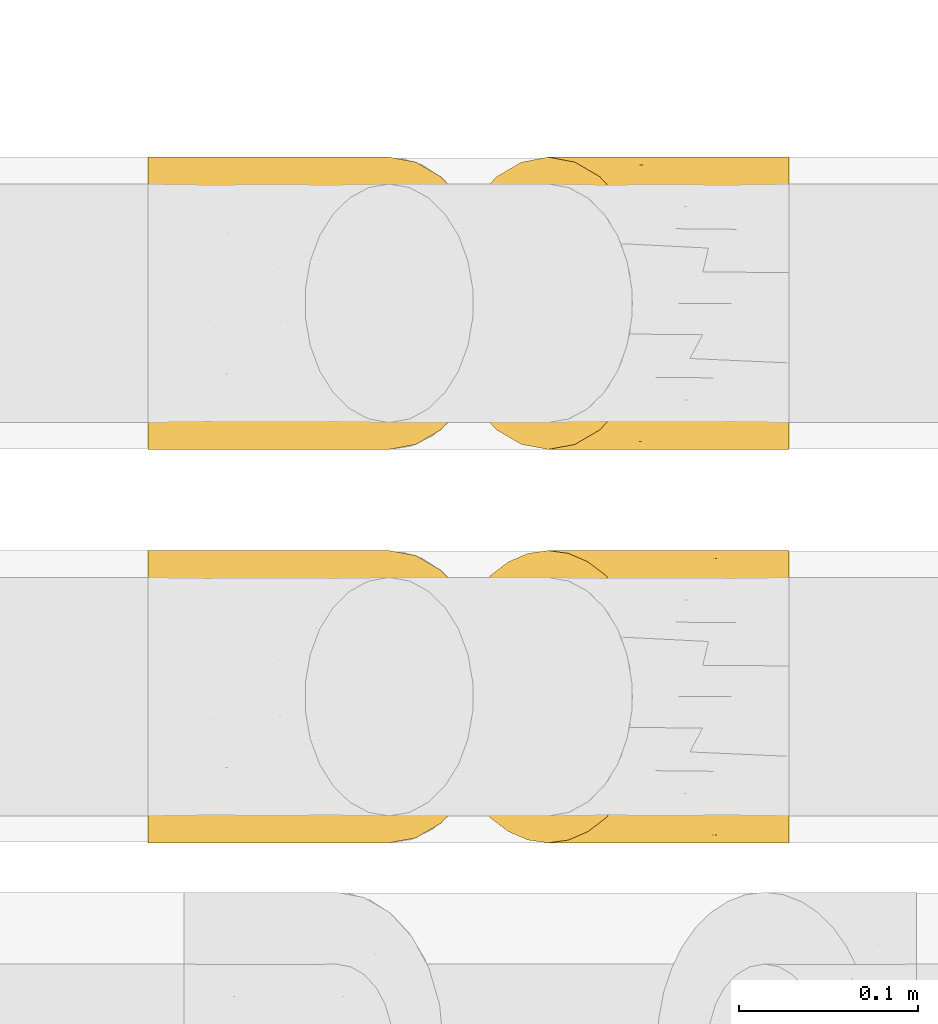
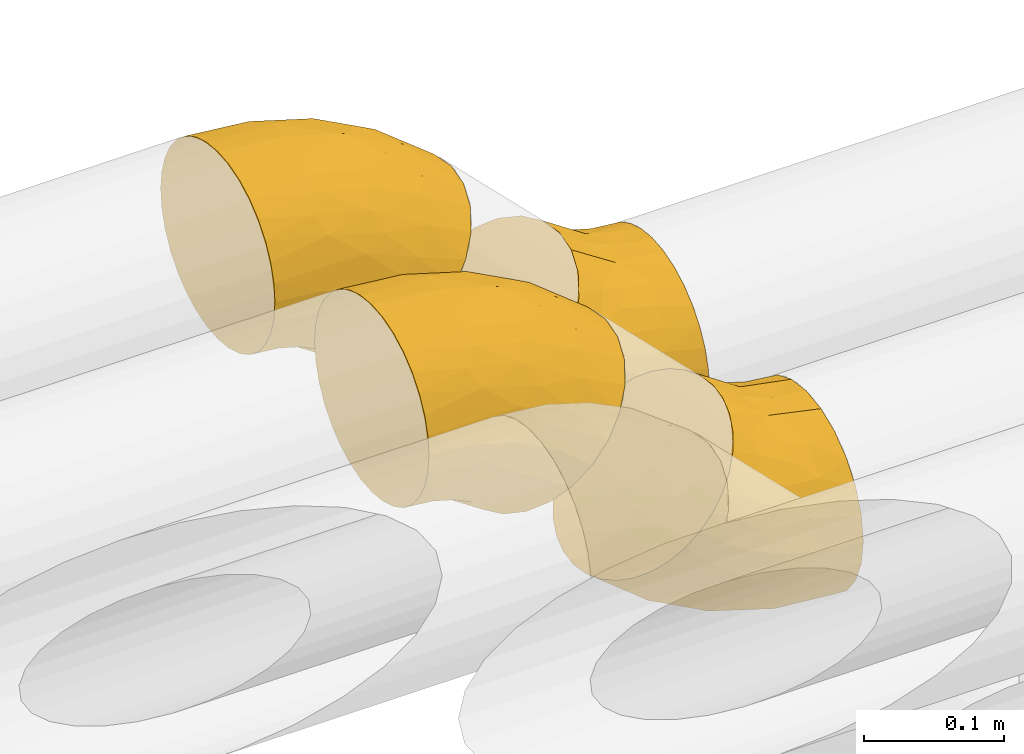
# One storey, part 28 of 93: 4 coverings.
"""IFC2X3 building model written with IfcOpenShell, lengths in millimetres."""

import ifcopenshell
import ifcopenshell.guid

model = None  # the IFC model being written
_history = None  # IfcOwnerHistory: only IFC2X3 demands one
_inside = {}  # id of a spatial element -> (the spatial element, [elements in it])
_under = {}  # id of a project, library or spatial element -> (it, [spatial elements below it])
_declared = {}  # id of a project -> (the project, [libraries it declares])
_typed = {}  # id of a type object -> (the type object, [elements of that type])
_made_of = {}  # id of a material, layer set ... -> (it, [elements and type objects made of it])


def new_model(schema):
    """Start an empty IFC model of exactly this schema.

    Asked for "IFC4X3", IfcOpenShell would pick the latest addendum, in which some entities
    have other attributes; the version numbers below select the first issue.
    IFC2X3 requires an IfcOwnerHistory on every rooted entity: one is made here for all.
    """
    global model, _history
    if schema == "IFC4X3":
        model = ifcopenshell.file(schema_version=(4, 3, 0, 0))
    else:
        model = ifcopenshell.file(schema=schema)
    _inside.clear()
    _under.clear()
    _declared.clear()
    _typed.clear()
    _made_of.clear()
    _history = None
    if model.schema == "IFC2X3":
        org = make("IfcOrganization", Name="unknown")
        user = make(
            "IfcPersonAndOrganization",
            ThePerson=make("IfcPerson", FamilyName="unknown"),
            TheOrganization=org,
        )
        app = make(
            "IfcApplication",
            ApplicationDeveloper=org,
            Version="unknown",
            ApplicationFullName="unknown",
            ApplicationIdentifier="unknown",
        )
        _history = make(
            "IfcOwnerHistory",
            OwningUser=user,
            OwningApplication=app,
            ChangeAction="ADDED",
            CreationDate=0,
        )
    return model


def make(cls, **values):
    """One entity of the class cls with the attributes given. An attribute that is None is left unset."""
    return model.create_entity(
        cls, **{name: value for name, value in values.items() if value is not None}
    )


def entity(cls, *values):
    """Any entity or typed value of the class cls, its attributes in the order of the schema. None: left unset."""
    e = model.create_entity(cls)
    for i, value in enumerate(values):
        if value is not None:
            e[i] = value
    return e


def rooted(cls, **values):
    """An entity with a GlobalId (a new one), such as an element, a storey or a relation."""
    return make(cls, GlobalId=ifcopenshell.guid.new(), OwnerHistory=_history, **values)


def si_unit(unit_type, name, prefix=None):
    """IfcSIUnit, for example si_unit("LENGTHUNIT", "METRE", prefix="MILLI")."""
    return make("IfcSIUnit", UnitType=unit_type, Prefix=prefix, Name=name)


def converted_unit(unit_type, name, factor, base, dimensions=None, offset=None):
    """IfcConversionBasedUnit, such as the inch: factor (a typed value) times the base unit."""
    return make(
        "IfcConversionBasedUnit"
        if offset is None
        else "IfcConversionBasedUnitWithOffset",
        ConversionOffset=offset,
        Dimensions=None
        if dimensions is None
        else entity("IfcDimensionalExponents", *dimensions),
        UnitType=unit_type,
        Name=name,
        ConversionFactor=make(
            "IfcMeasureWithUnit", ValueComponent=factor, UnitComponent=base
        ),
    )


def derived_unit(unit_type, elements):
    """IfcDerivedUnit: a product of units, each with its exponent."""
    return make(
        "IfcDerivedUnit",
        Elements=[
            make("IfcDerivedUnitElement", Unit=unit, Exponent=power)
            for unit, power in elements
        ],
        UnitType=unit_type,
    )


def assignment(units):
    """IfcUnitAssignment: the units of a project."""
    return None if units is None else make("IfcUnitAssignment", Units=units)


def point(xyz):
    """IfcCartesianPoint."""
    return None if xyz is None else make("IfcCartesianPoint", Coordinates=xyz)


def direction(xyz):
    """IfcDirection."""
    return None if xyz is None else make("IfcDirection", DirectionRatios=xyz)


def frame(location, z_axis=None, x_axis=None):
    """IfcAxis2Placement3D, a coordinate frame: its origin and axes. An axis left out is left unset."""
    return make(
        "IfcAxis2Placement3D",
        Location=point(location),
        Axis=direction(z_axis),
        RefDirection=direction(x_axis),
    )


def origin():
    """The frame at (0, 0, 0) with its axes left unset."""
    return frame((0.0, 0.0, 0.0))


def place(relative_to, where):
    """IfcLocalPlacement: puts the frame where relative to a parent placement (None: the world)."""
    return make(
        "IfcLocalPlacement", PlacementRelTo=relative_to, RelativePlacement=where
    )


def context(
    kind, dimensions, precision=None, world=None, true_north=None, identifier=None
):
    """IfcGeometricRepresentationContext, for example the 3D "Model" context."""
    return make(
        "IfcGeometricRepresentationContext",
        ContextIdentifier=identifier,
        ContextType=kind,
        CoordinateSpaceDimension=dimensions,
        Precision=precision,
        WorldCoordinateSystem=world,
        TrueNorth=true_north,
    )


def subcontext(parent, identifier, kind, view, scale=None):
    """IfcGeometricRepresentationSubContext, for example "Body" below "Model"."""
    return make(
        "IfcGeometricRepresentationSubContext",
        ContextIdentifier=identifier,
        ContextType=kind,
        ParentContext=parent,
        TargetScale=scale,
        TargetView=view,
    )


def project(units=None, contexts=None):
    """IfcProject with its units and contexts."""
    return rooted(
        "IfcProject",
        Name="project",
        RepresentationContexts=contexts,
        UnitsInContext=assignment(units),
    )


def spatial(cls, under=None, at=None, **own):
    """A site, building, storey or space (cls), placed at a placement, below another one or the project."""
    s = rooted(cls, ObjectPlacement=at, **own)
    if under is not None:
        _under.setdefault(under.id(), (under, []))[1].append(s)
    return s


def faces_of(points, faces, orient=None, outer=None):
    """IfcFace entities. A face is a list of loops; a loop is a list of indices into points, from 0.

    orient and outer hold one flag for each loop. By default every Orientation is true, the
    first loop of a face is its IfcFaceOuterBound and the others are IfcFaceBound.
    """
    made = []
    for i, loops in enumerate(faces):
        bounds = []
        for j, loop in enumerate(loops):
            is_outer = j == 0 if outer is None else outer[i][j]
            bounds.append(
                make(
                    "IfcFaceOuterBound" if is_outer else "IfcFaceBound",
                    Bound=make("IfcPolyLoop", Polygon=[points[k] for k in loop]),
                    Orientation=True if orient is None else orient[i][j],
                )
            )
        made.append(make("IfcFace", Bounds=bounds))
    return made


def faceted_brep(points, faces, orient=None, outer=None, voids=None):
    """IfcFacetedBrep: a solid bounded by flat faces; with voids (closed shells), ...WithVoids."""
    shared = [point(p) for p in points]
    hull = make("IfcClosedShell", CfsFaces=faces_of(shared, faces, orient, outer))
    if voids is None:
        return make("IfcFacetedBrep", Outer=hull)
    return make(
        "IfcFacetedBrepWithVoids",
        Outer=hull,
        Voids=[
            make(cls, CfsFaces=faces_of(shared, fs, o, b)) for cls, fs, o, b in voids
        ],
    )


def shape(context_of_items, identifier, shape_type, items):
    """IfcShapeRepresentation: the items that make up one representation, for example the "Body"."""
    return make(
        "IfcShapeRepresentation",
        ContextOfItems=context_of_items,
        RepresentationIdentifier=identifier,
        RepresentationType=shape_type,
        Items=items,
    )


def made_of(thing, what):
    """Note that an element or type object is made of a material, layer set ...; save() writes the relation."""
    if what is not None:
        _made_of.setdefault(what.id(), (what, []))[1].append(thing)
    return thing


def element(
    cls,
    number,
    at=None,
    inside=None,
    cuts=None,
    type_object=None,
    material=None,
    context=None,
    identifier="Body",
    shape_type=None,
    held_by="IfcProductDefinitionShape",
    body=None,
    shapes=None,
    **own,
):
    """One element of the class cls, such as IfcWall. Its Tag is "e" and its number.

    at: its placement. inside: the storey or other place that contains it. cuts: it is an
    opening in that element (IfcRelVoidsElement). A single representation is given by context,
    identifier, shape_type and body (its items); several are given by shapes. held_by: the class
    of the entity that holds the representations. save() writes the other relations.
    """
    e = rooted(cls, Tag="e%d" % number, ObjectPlacement=at, **own)
    if body is not None:
        shapes = [shape(context, identifier, shape_type, body)]
    if shapes is not None:
        e.Representation = make(held_by, Representations=shapes)
    if inside is not None:
        _inside.setdefault(inside.id(), (inside, []))[1].append(e)
    if cuts is not None:
        rooted(
            "IfcRelVoidsElement", RelatingBuildingElement=cuts, RelatedOpeningElement=e
        )
    if type_object is not None:
        _typed.setdefault(type_object.id(), (type_object, []))[1].append(e)
    return made_of(e, material)


def aggregate(whole, parts):
    """IfcRelAggregates: a whole, such as a stair, and the parts it consists of."""
    return rooted("IfcRelAggregates", RelatingObject=whole, RelatedObjects=parts)


def save(model, path):
    """Write the relations noted so far, then the file.

    IfcRelAggregates (storeys below a building ...), IfcRelContainedInSpatialStructure (elements
    in a storey), IfcRelDefinesByType, IfcRelAssociatesMaterial and IfcRelDeclares: one each for
    every whole, place, type object, material and project.
    """
    for whole, parts in _under.values():
        aggregate(whole, parts)
    for where, things in _inside.values():
        rooted(
            "IfcRelContainedInSpatialStructure",
            RelatedElements=things,
            RelatingStructure=where,
        )
    for kind, things in _typed.values():
        rooted("IfcRelDefinesByType", RelatedObjects=things, RelatingType=kind)
    for what, things in _made_of.values():
        rooted("IfcRelAssociatesMaterial", RelatedObjects=things, RelatingMaterial=what)
    for by, libraries in _declared.values():
        rooted("IfcRelDeclares", RelatingContext=by, RelatedDefinitions=libraries)
    model.write(path)


model = new_model("IFC2X3")

# Units and contexts
model_context = context("Model", 3, precision=0.01, world=origin(), true_north=direction((6.12303176911189e-17, 1.0)))
body_context = subcontext(model_context, "Body", "Model", "MODEL_VIEW")
ifc_project = project(units=[si_unit("LENGTHUNIT", "METRE", prefix="MILLI"), si_unit("AREAUNIT", "SQUARE_METRE"), si_unit("VOLUMEUNIT", "CUBIC_METRE"), converted_unit("PLANEANGLEUNIT", "DEGREE", entity("IfcRatioMeasure", 0.0174532925199433), si_unit("PLANEANGLEUNIT", "RADIAN"), dimensions=[0, 0, 0, 0, 0, 0, 0]), si_unit("MASSUNIT", "GRAM", prefix="KILO"), derived_unit("MASSDENSITYUNIT", [(si_unit("MASSUNIT", "GRAM", prefix="KILO"), 1), (si_unit("LENGTHUNIT", "METRE"), -3)]), derived_unit("MOMENTOFINERTIAUNIT", [(si_unit("LENGTHUNIT", "METRE"), 4)]), si_unit("TIMEUNIT", "SECOND"), si_unit("FREQUENCYUNIT", "HERTZ"), si_unit("THERMODYNAMICTEMPERATUREUNIT", "DEGREE_CELSIUS"), derived_unit("THERMALTRANSMITTANCEUNIT", [(si_unit("MASSUNIT", "GRAM", prefix="KILO"), 1), (si_unit("THERMODYNAMICTEMPERATUREUNIT", "KELVIN"), -1), (si_unit("TIMEUNIT", "SECOND"), -3)]), derived_unit("VOLUMETRICFLOWRATEUNIT", [(si_unit("LENGTHUNIT", "METRE"), 3), (si_unit("TIMEUNIT", "SECOND"), -1)]), derived_unit("MASSFLOWRATEUNIT", [(si_unit("MASSUNIT", "GRAM", prefix="KILO"), 1), (si_unit("TIMEUNIT", "SECOND"), -1)]), derived_unit("ROTATIONALFREQUENCYUNIT", [(si_unit("TIMEUNIT", "SECOND"), -1)]), si_unit("ELECTRICCURRENTUNIT", "AMPERE"), si_unit("ELECTRICVOLTAGEUNIT", "VOLT"), si_unit("POWERUNIT", "WATT"), si_unit("FORCEUNIT", "NEWTON", prefix="KILO"), si_unit("ILLUMINANCEUNIT", "LUX"), si_unit("LUMINOUSFLUXUNIT", "LUMEN"), si_unit("LUMINOUSINTENSITYUNIT", "CANDELA"), derived_unit("USERDEFINED", [(si_unit("MASSUNIT", "GRAM", prefix="KILO"), -1), (si_unit("LENGTHUNIT", "METRE"), -2), (si_unit("TIMEUNIT", "SECOND"), 3), (si_unit("LUMINOUSFLUXUNIT", "LUMEN"), 1)]), derived_unit("LINEARVELOCITYUNIT", [(si_unit("LENGTHUNIT", "METRE"), 1), (si_unit("TIMEUNIT", "SECOND"), -1)]), si_unit("PRESSUREUNIT", "PASCAL"), derived_unit("USERDEFINED", [(si_unit("LENGTHUNIT", "METRE"), -2), (si_unit("MASSUNIT", "GRAM", prefix="KILO"), 1), (si_unit("TIMEUNIT", "SECOND"), -2)]), derived_unit("LINEARFORCEUNIT", [(si_unit("MASSUNIT", "GRAM", prefix="KILO"), 1), (si_unit("LENGTHUNIT", "METRE"), 1), (si_unit("TIMEUNIT", "SECOND"), -2), (si_unit("LENGTHUNIT", "METRE"), -1)]), derived_unit("PLANARFORCEUNIT", [(si_unit("MASSUNIT", "GRAM", prefix="KILO"), 1), (si_unit("LENGTHUNIT", "METRE"), 1), (si_unit("TIMEUNIT", "SECOND"), -2), (si_unit("LENGTHUNIT", "METRE"), -2)])], contexts=[model_context])

# Site, building, storey
site_placement = place(None, origin())
site = spatial("IfcSite", under=ifc_project, at=site_placement, CompositionType="ELEMENT")
building_placement = place(site_placement, origin())
building = spatial("IfcBuilding", under=site, at=building_placement, CompositionType="ELEMENT")
storey_placement = place(building_placement, frame((0.0, 0.0, -4200.0)))
storey = spatial("IfcBuildingStorey", under=building, at=storey_placement, CompositionType="ELEMENT", Elevation=-4200.0)

# Coverings
covering_1_placement = place(storey_placement, frame((22851.57, 9391.04, 2885.13)))
element("IfcCovering", 1, at=covering_1_placement, inside=storey, Name=":ADSK_", ObjectType=":ADSK_", PredefinedType="INSULATION", context=body_context, shape_type="Brep", body=[
    faceted_brep([(1.6, 67.2, 34.94), (1.6, 51.91, 39.58), (1.6, 37.82, 47.11), (1.6, 25.47, 57.25), (1.6, 15.33, 69.6), (1.6, 7.8, 83.69), (1.6, 3.16, 98.98), (1.6, 1.6, 114.87), (1.6, 3.16, 130.77), (1.6, 7.8, 146.06), (1.6, 15.33, 160.15), (1.6, 25.47, 172.5), (1.6, 37.82, 182.64), (1.6, 51.91, 190.17), (1.6, 67.2, 194.81), (1.6, 83.1, 196.37), (1.6, 99.0, 194.81), (1.6, 114.28, 190.17), (1.6, 128.37, 182.64), (1.6, 140.72, 172.5), (1.6, 150.86, 160.15), (1.6, 158.39, 146.06), (1.6, 163.03, 130.77), (1.6, 164.6, 114.87), (1.6, 163.03, 98.97), (1.6, 158.39, 83.69), (1.6, 150.86, 69.59), (1.6, 140.72, 57.24), (1.6, 128.37, 47.11), (1.6, 114.28, 39.58), (1.6, 98.99, 34.94), (1.6, 83.1, 33.37), (80.28, 104.19, 3.56), (86.04, 123.85, 9.32), (95.2, 140.72, 18.47), (107.13, 153.68, 30.41), (121.03, 161.82, 44.31), (135.95, 164.6, 59.22), (150.86, 161.82, 74.14), (164.76, 153.68, 88.04), (176.7, 140.72, 99.97), (185.85, 123.85, 109.13), (191.61, 104.19, 114.89), (193.57, 83.1, 116.85), (191.61, 62.0, 114.89), (185.85, 42.35, 109.13), (176.7, 25.47, 99.97), (164.76, 12.51, 88.04), (150.86, 4.37, 74.14), (135.95, 1.6, 59.22), (121.03, 4.37, 44.31), (107.13, 12.51, 30.41), (95.2, 25.47, 18.47), (86.04, 42.35, 9.32), (80.28, 62.0, 3.56), (78.32, 83.1, 1.6), (60.3, 60.17, 186.58), (100.98, 46.35, 168.1), (128.84, 64.11, 162.17), (152.43, 83.1, 150.62), (105.49, 83.1, 175.71), (139.75, 34.49, 139.7), (150.3, 49.6, 143.37), (51.57, 12.07, 149.35), (54.56, 83.1, 191.16), (107.15, 1.6, 82.85), (104.29, 3.08, 102.85), (74.31, 1.6, 100.41), (98.84, 12.62, 134.33), (91.29, 21.86, 151.55), (54.87, 45.58, 181.76), (137.35, 19.56, 124.06), (123.1, 7.29, 108.18), (79.11, 6.1, 127.27), (99.6, 33.79, 160.17), (44.25, 21.05, 163.94), (56.41, 32.43, 172.72), (38.66, 1.6, 111.22), (44.11, 62.69, 27.51), (22.65, 43.46, 41.78), (84.3, 5.92, 66.25), (50.27, 3.26, 91.51), (60.78, 8.71, 69.97), (79.3, 19.34, 40.4), (29.25, 18.22, 62.8), (56.24, 16.65, 56.8), (35.2, 9.42, 76.35), (30.87, 29.5, 50.1), (58.8, 28.17, 41.38), (68.75, 38.07, 26.81), (55.85, 83.1, 18.84), (46.59, 42.04, 35.68), (24.22, 4.27, 92.66), (29.68, 83.1, 29.68), (46.59, 124.15, 35.68), (58.8, 138.02, 41.38), (68.75, 128.12, 26.81), (50.27, 162.93, 91.51), (84.3, 160.27, 66.25), (60.78, 157.48, 69.97), (44.11, 103.5, 27.51), (35.2, 156.77, 76.35), (24.22, 161.92, 92.65), (56.24, 149.54, 56.8), (30.87, 136.69, 50.1), (107.15, 164.6, 82.85), (79.3, 146.85, 40.4), (74.31, 164.6, 100.41), (22.65, 122.73, 41.78), (38.66, 164.6, 111.22), (26.81, 147.88, 63.14), (79.1, 160.09, 127.27), (123.1, 158.9, 108.18), (104.28, 163.11, 102.85), (137.35, 146.63, 124.06), (51.57, 154.12, 149.35), (98.84, 153.57, 134.33), (91.29, 144.33, 151.55), (139.75, 131.7, 139.7), (150.3, 116.59, 143.37), (100.98, 119.84, 168.1), (60.3, 106.02, 186.58), (128.84, 102.08, 162.17), (56.41, 133.76, 172.72), (44.25, 145.14, 163.94), (99.62, 133.61, 159.15), (45.37, 120.65, 183.53)], [[[0, 1, 2, 3, 4, 5, 6, 7, 8, 9, 10, 11, 12, 13, 14, 15, 16, 17, 18, 19, 20, 21, 22, 23, 24, 25, 26, 27, 28, 29, 30, 31]], [[32, 33, 34, 35, 36, 37, 38, 39, 40, 41, 42, 43, 44, 45, 46, 47, 48, 49, 50, 51, 52, 53, 54, 55]], [[56, 57, 58]], [[44, 43, 59]], [[58, 59, 60]], [[60, 56, 58]], [[45, 61, 46]], [[61, 45, 62]], [[9, 63, 10]], [[64, 14, 56]], [[65, 66, 67]], [[68, 69, 63]], [[57, 61, 62]], [[70, 57, 56]], [[47, 71, 72]], [[49, 48, 66]], [[72, 66, 48]], [[9, 73, 63]], [[71, 69, 68]], [[44, 59, 58]], [[64, 56, 60]], [[74, 69, 61]], [[10, 63, 75]], [[70, 76, 74]], [[70, 12, 76]], [[14, 64, 15]], [[66, 72, 73]], [[61, 71, 46]], [[44, 58, 62]], [[71, 68, 72]], [[77, 8, 7]], [[67, 73, 77]], [[75, 69, 76]], [[75, 76, 11]], [[77, 73, 8]], [[73, 9, 8]], [[72, 68, 73]], [[71, 61, 69]], [[12, 11, 76]], [[74, 61, 57]], [[71, 47, 46]], [[56, 14, 13]], [[47, 72, 48]], [[68, 63, 73]], [[67, 66, 73]], [[66, 65, 49]], [[44, 62, 45]], [[57, 62, 58]], [[10, 75, 11]], [[63, 69, 75]], [[56, 13, 70]], [[12, 70, 13]], [[70, 74, 57]], [[69, 74, 76]], [[78, 79, 1]], [[50, 49, 65]], [[80, 67, 81]], [[82, 83, 80]], [[84, 85, 86]], [[85, 84, 87]], [[88, 89, 83]], [[50, 65, 80]], [[82, 86, 85]], [[87, 88, 85]], [[54, 90, 55]], [[89, 78, 54]], [[87, 79, 91]], [[0, 78, 1]], [[89, 54, 53]], [[54, 78, 90]], [[86, 5, 4]], [[52, 51, 83]], [[2, 79, 87]], [[84, 3, 87]], [[88, 87, 91]], [[81, 92, 86]], [[7, 6, 77]], [[91, 79, 78]], [[81, 86, 82]], [[89, 88, 91]], [[93, 0, 31]], [[78, 0, 93]], [[83, 85, 88]], [[67, 80, 65]], [[83, 89, 52]], [[90, 78, 93]], [[1, 79, 2]], [[50, 80, 51]], [[2, 87, 3]], [[77, 81, 67]], [[92, 77, 6]], [[6, 5, 92]], [[86, 92, 5]], [[80, 83, 51]], [[77, 92, 81]], [[89, 91, 78]], [[52, 89, 53]], [[83, 82, 85]], [[81, 82, 80]], [[86, 4, 84]], [[3, 84, 4]], [[94, 95, 96]], [[97, 98, 99]], [[32, 55, 90]], [[96, 32, 100]], [[101, 25, 102]], [[32, 90, 100]], [[99, 103, 101]], [[94, 104, 95]], [[37, 36, 105]], [[106, 95, 103]], [[36, 35, 98]], [[98, 107, 105]], [[104, 108, 28]], [[35, 106, 98]], [[95, 104, 103]], [[105, 36, 98]], [[100, 90, 93]], [[109, 102, 24]], [[93, 31, 30]], [[35, 34, 106]], [[26, 25, 101]], [[96, 106, 34]], [[28, 108, 29]], [[100, 29, 108]], [[28, 27, 104]], [[108, 104, 94]], [[110, 103, 104]], [[101, 110, 26]], [[25, 24, 102]], [[97, 109, 107]], [[100, 94, 96]], [[27, 26, 110]], [[24, 23, 109]], [[97, 102, 109]], [[100, 108, 94]], [[30, 100, 93]], [[106, 103, 99]], [[30, 29, 100]], [[98, 97, 107]], [[96, 34, 33]], [[101, 102, 97]], [[96, 95, 106]], [[32, 96, 33]], [[97, 99, 101]], [[106, 99, 98]], [[103, 110, 101]], [[27, 110, 104]], [[111, 112, 113]], [[112, 39, 38]], [[39, 112, 114]], [[111, 115, 116]], [[111, 113, 107]], [[105, 113, 37]], [[114, 116, 117]], [[112, 111, 116]], [[59, 43, 42]], [[38, 37, 113]], [[112, 116, 114]], [[118, 119, 41]], [[120, 121, 122]], [[123, 124, 19]], [[120, 122, 119]], [[60, 59, 122]], [[39, 114, 40]], [[115, 21, 20]], [[107, 109, 111]], [[114, 117, 125]], [[109, 23, 22]], [[118, 41, 40]], [[21, 115, 111]], [[116, 115, 117]], [[124, 20, 19]], [[22, 21, 111]], [[114, 118, 40]], [[19, 18, 123]], [[121, 126, 17]], [[117, 124, 123]], [[59, 42, 122]], [[60, 122, 121]], [[16, 15, 64]], [[18, 17, 126]], [[60, 121, 64]], [[120, 123, 126]], [[125, 120, 118]], [[16, 121, 17]], [[119, 42, 41]], [[111, 109, 22]], [[123, 125, 117]], [[16, 64, 121]], [[38, 113, 112]], [[107, 113, 105]], [[120, 119, 118]], [[42, 119, 122]], [[117, 115, 124]], [[20, 124, 115]], [[120, 126, 121]], [[18, 126, 123]], [[120, 125, 123]], [[114, 125, 118]]]),
])
covering_2_placement = place(storey_placement, frame((23016.99, 9171.64, 2716.9)))
element("IfcCovering", 2, at=covering_2_placement, inside=storey, Name=":ADSK_", ObjectType=":ADSK_", PredefinedType="INSULATION", context=body_context, shape_type="Brep", body=[
    faceted_brep([(115.75, 99.0, 195.27), (112.47, 114.28, 191.99), (107.14, 128.37, 186.66), (99.97, 140.72, 179.49), (91.24, 150.86, 170.76), (81.28, 158.39, 160.8), (70.47, 163.03, 149.99), (59.22, 164.6, 138.74), (47.98, 163.03, 127.5), (37.17, 158.39, 116.69), (27.21, 150.86, 106.73), (18.47, 140.72, 97.99), (11.31, 128.37, 90.83), (5.98, 114.28, 85.5), (2.7, 98.99, 82.22), (1.6, 83.1, 81.12), (2.7, 67.2, 82.22), (5.98, 51.91, 85.5), (11.31, 37.82, 90.83), (18.47, 25.47, 98.0), (27.21, 15.33, 106.73), (37.17, 7.8, 116.69), (47.98, 3.16, 127.5), (59.22, 1.6, 138.74), (70.47, 3.16, 149.99), (81.28, 7.8, 160.8), (91.24, 15.33, 170.76), (99.97, 25.47, 179.5), (107.14, 37.82, 186.66), (112.47, 51.91, 191.99), (115.75, 67.2, 195.27), (116.85, 83.1, 196.37), (193.57, 62.0, 161.82), (193.57, 42.35, 153.68), (193.57, 25.47, 140.72), (193.57, 12.51, 123.85), (193.57, 4.37, 104.19), (193.57, 1.6, 83.1), (193.57, 4.37, 62.0), (193.57, 12.51, 42.35), (193.57, 25.47, 25.47), (193.57, 42.35, 12.51), (193.57, 62.0, 4.37), (193.57, 83.1, 1.6), (193.57, 104.19, 4.37), (193.57, 123.85, 12.51), (193.57, 140.72, 25.47), (193.57, 153.68, 42.35), (193.57, 161.82, 62.0), (193.57, 164.6, 83.1), (193.57, 161.82, 104.19), (193.57, 153.68, 123.85), (193.57, 140.72, 140.72), (193.57, 123.85, 153.68), (193.57, 104.19, 161.82), (193.57, 83.1, 164.6), (50.03, 106.02, 46.53), (91.87, 119.84, 30.83), (115.75, 102.08, 15.33), (140.61, 83.1, 6.81), (89.68, 83.1, 22.26), (139.36, 131.7, 23.5), (144.23, 116.59, 13.44), (70.18, 154.12, 79.03), (42.74, 83.1, 47.35), (156.51, 164.6, 86.75), (140.34, 163.11, 74.64), (120.86, 164.6, 97.56), (114.23, 153.57, 56.22), (96.72, 144.33, 49.38), (49.6, 120.61, 53.78), (148.72, 146.63, 36.26), (149.88, 158.9, 57.56), (105.27, 160.09, 75.17), (96.49, 132.4, 37.42), (54.69, 145.14, 73.89), (57.09, 133.76, 59.08), (88.02, 164.6, 115.12), (151.06, 103.5, 170.46), (125.8, 122.73, 175.54), (152.09, 160.27, 114.64), (110.16, 162.93, 120.85), (132.83, 157.48, 128.64), (166.83, 146.85, 136.46), (115.6, 147.97, 156.01), (138.93, 149.54, 141.17), (110.22, 156.77, 142.22), (125.72, 136.69, 163.85), (151.64, 138.02, 150.27), (168.98, 128.12, 153.53), (165.49, 83.1, 168.29), (147.04, 124.15, 162.93), (90.93, 161.92, 138.46), (139.32, 83.1, 179.13), (147.04, 42.04, 162.93), (151.65, 28.17, 150.27), (168.98, 38.07, 153.53), (110.16, 3.26, 120.85), (152.09, 5.92, 114.64), (132.83, 8.71, 128.64), (151.06, 62.69, 170.46), (110.22, 9.42, 142.22), (90.93, 4.27, 138.46), (138.93, 16.66, 141.17), (125.73, 29.5, 163.85), (156.51, 1.6, 86.75), (166.83, 19.34, 136.46), (120.86, 1.6, 97.56), (125.8, 43.46, 175.54), (88.02, 1.6, 115.12), (113.64, 18.32, 157.5), (105.27, 6.1, 75.17), (149.87, 7.29, 57.56), (140.34, 3.08, 74.64), (148.72, 19.56, 36.26), (70.18, 12.07, 79.03), (114.23, 12.62, 56.22), (96.72, 21.86, 49.38), (139.36, 34.49, 23.5), (144.23, 49.6, 13.44), (91.87, 46.35, 30.83), (50.03, 60.17, 46.53), (115.75, 64.11, 15.33), (57.09, 32.43, 59.08), (54.69, 21.05, 73.89), (97.23, 32.58, 38.13), (41.63, 45.54, 59.25)], [[[0, 1, 2, 3, 4, 5, 6, 7, 8, 9, 10, 11, 12, 13, 14, 15, 16, 17, 18, 19, 20, 21, 22, 23, 24, 25, 26, 27, 28, 29, 30, 31]], [[32, 33, 34, 35, 36, 37, 38, 39, 40, 41, 42, 43, 44, 45, 46, 47, 48, 49, 50, 51, 52, 53, 54, 55]], [[56, 57, 58]], [[44, 43, 59]], [[58, 59, 60]], [[60, 56, 58]], [[45, 61, 46]], [[61, 45, 62]], [[9, 63, 10]], [[64, 14, 56]], [[65, 66, 67]], [[68, 69, 63]], [[57, 61, 62]], [[70, 57, 56]], [[47, 71, 72]], [[49, 48, 66]], [[72, 66, 48]], [[9, 73, 63]], [[71, 69, 68]], [[44, 59, 58]], [[64, 56, 60]], [[74, 69, 61]], [[10, 63, 75]], [[70, 76, 74]], [[70, 12, 76]], [[14, 64, 15]], [[66, 72, 73]], [[61, 71, 46]], [[44, 58, 62]], [[71, 68, 72]], [[77, 8, 7]], [[67, 73, 77]], [[75, 69, 76]], [[75, 76, 11]], [[77, 73, 8]], [[73, 9, 8]], [[72, 68, 73]], [[71, 61, 69]], [[12, 11, 76]], [[74, 61, 57]], [[71, 47, 46]], [[56, 14, 13]], [[47, 72, 48]], [[68, 63, 73]], [[67, 66, 73]], [[66, 65, 49]], [[44, 62, 45]], [[57, 62, 58]], [[10, 75, 11]], [[63, 69, 75]], [[56, 13, 70]], [[12, 70, 13]], [[70, 74, 57]], [[69, 74, 76]], [[78, 79, 1]], [[50, 49, 65]], [[80, 67, 81]], [[82, 83, 80]], [[84, 85, 86]], [[85, 84, 87]], [[88, 89, 83]], [[50, 65, 80]], [[82, 86, 85]], [[87, 88, 85]], [[54, 90, 55]], [[89, 78, 54]], [[87, 79, 91]], [[0, 78, 1]], [[89, 54, 53]], [[54, 78, 90]], [[86, 5, 4]], [[52, 51, 83]], [[2, 79, 87]], [[84, 3, 87]], [[88, 87, 91]], [[81, 92, 86]], [[7, 6, 77]], [[91, 79, 78]], [[81, 86, 82]], [[89, 88, 91]], [[93, 0, 31]], [[78, 0, 93]], [[83, 85, 88]], [[67, 80, 65]], [[83, 89, 52]], [[90, 78, 93]], [[1, 79, 2]], [[50, 80, 51]], [[2, 87, 3]], [[77, 81, 67]], [[92, 77, 6]], [[6, 5, 92]], [[86, 92, 5]], [[80, 83, 51]], [[77, 92, 81]], [[89, 91, 78]], [[52, 89, 53]], [[83, 82, 85]], [[81, 82, 80]], [[86, 4, 84]], [[3, 84, 4]], [[94, 95, 96]], [[97, 98, 99]], [[32, 55, 90]], [[96, 32, 100]], [[101, 25, 102]], [[32, 90, 100]], [[99, 103, 101]], [[94, 104, 95]], [[37, 36, 105]], [[106, 95, 103]], [[36, 35, 98]], [[98, 107, 105]], [[104, 108, 28]], [[35, 106, 98]], [[95, 104, 103]], [[105, 36, 98]], [[100, 90, 93]], [[109, 102, 24]], [[93, 31, 30]], [[35, 34, 106]], [[26, 25, 101]], [[96, 106, 34]], [[28, 108, 29]], [[100, 29, 108]], [[28, 27, 104]], [[108, 104, 94]], [[110, 103, 104]], [[101, 110, 26]], [[25, 24, 102]], [[97, 109, 107]], [[100, 94, 96]], [[27, 26, 110]], [[24, 23, 109]], [[97, 102, 109]], [[100, 108, 94]], [[30, 100, 93]], [[106, 103, 99]], [[30, 29, 100]], [[98, 97, 107]], [[96, 34, 33]], [[101, 102, 97]], [[96, 95, 106]], [[32, 96, 33]], [[97, 99, 101]], [[106, 99, 98]], [[103, 110, 101]], [[27, 110, 104]], [[111, 112, 113]], [[112, 39, 38]], [[39, 112, 114]], [[111, 115, 116]], [[111, 113, 107]], [[105, 113, 37]], [[114, 116, 117]], [[112, 111, 116]], [[59, 43, 42]], [[38, 37, 113]], [[112, 116, 114]], [[118, 119, 41]], [[120, 121, 122]], [[123, 124, 19]], [[120, 122, 119]], [[60, 59, 122]], [[39, 114, 40]], [[115, 21, 20]], [[107, 109, 111]], [[114, 117, 125]], [[109, 23, 22]], [[118, 41, 40]], [[21, 115, 111]], [[116, 115, 117]], [[124, 20, 19]], [[22, 21, 111]], [[114, 118, 40]], [[19, 18, 123]], [[121, 126, 17]], [[117, 124, 123]], [[59, 42, 122]], [[60, 122, 121]], [[16, 15, 64]], [[18, 17, 126]], [[60, 121, 64]], [[120, 123, 126]], [[125, 120, 118]], [[16, 121, 17]], [[119, 42, 41]], [[111, 109, 22]], [[123, 125, 117]], [[16, 64, 121]], [[38, 113, 112]], [[107, 113, 105]], [[120, 119, 118]], [[42, 119, 122]], [[117, 115, 124]], [[20, 124, 115]], [[120, 126, 121]], [[18, 126, 123]], [[120, 125, 123]], [[114, 125, 118]]]),
])
covering_3_placement = place(storey_placement, frame((22851.57, 9171.64, 2885.13)))
element("IfcCovering", 3, at=covering_3_placement, inside=storey, Name=":ADSK_", ObjectType=":ADSK_", PredefinedType="INSULATION", context=body_context, shape_type="Brep", body=[
    faceted_brep([(1.6, 67.2, 34.94), (1.6, 51.91, 39.58), (1.6, 37.82, 47.11), (1.6, 25.47, 57.25), (1.6, 15.33, 69.6), (1.6, 7.8, 83.69), (1.6, 3.16, 98.98), (1.6, 1.6, 114.87), (1.6, 3.16, 130.77), (1.6, 7.8, 146.06), (1.6, 15.33, 160.15), (1.6, 25.47, 172.5), (1.6, 37.82, 182.64), (1.6, 51.91, 190.17), (1.6, 67.2, 194.81), (1.6, 83.1, 196.37), (1.6, 99.0, 194.81), (1.6, 114.28, 190.17), (1.6, 128.37, 182.64), (1.6, 140.72, 172.5), (1.6, 150.86, 160.15), (1.6, 158.39, 146.06), (1.6, 163.03, 130.77), (1.6, 164.6, 114.87), (1.6, 163.03, 98.97), (1.6, 158.39, 83.69), (1.6, 150.86, 69.59), (1.6, 140.72, 57.24), (1.6, 128.37, 47.11), (1.6, 114.28, 39.58), (1.6, 98.99, 34.94), (1.6, 83.1, 33.37), (80.28, 104.19, 3.56), (86.04, 123.85, 9.32), (95.2, 140.72, 18.47), (107.13, 153.68, 30.41), (121.03, 161.82, 44.31), (135.95, 164.6, 59.22), (150.86, 161.82, 74.14), (164.76, 153.68, 88.04), (176.7, 140.72, 99.97), (185.85, 123.85, 109.13), (191.61, 104.19, 114.89), (193.57, 83.1, 116.85), (191.61, 62.0, 114.89), (185.85, 42.35, 109.13), (176.7, 25.47, 99.97), (164.76, 12.51, 88.04), (150.86, 4.37, 74.14), (135.95, 1.6, 59.22), (121.03, 4.37, 44.31), (107.13, 12.51, 30.41), (95.2, 25.47, 18.47), (86.04, 42.35, 9.32), (80.28, 62.0, 3.56), (78.32, 83.1, 1.6), (60.3, 60.17, 186.58), (100.98, 46.35, 168.1), (128.84, 64.11, 162.17), (152.43, 83.1, 150.62), (105.49, 83.1, 175.71), (139.75, 34.49, 139.7), (150.3, 49.6, 143.37), (51.57, 12.07, 149.35), (54.56, 83.1, 191.16), (107.15, 1.6, 82.85), (104.29, 3.08, 102.85), (74.31, 1.6, 100.41), (98.84, 12.62, 134.33), (91.29, 21.86, 151.55), (54.87, 45.58, 181.76), (137.35, 19.56, 124.06), (123.1, 7.29, 108.18), (79.11, 6.1, 127.27), (99.6, 33.79, 160.17), (44.25, 21.05, 163.94), (56.41, 32.43, 172.72), (38.66, 1.6, 111.22), (44.11, 62.69, 27.51), (22.65, 43.46, 41.78), (84.3, 5.92, 66.25), (50.27, 3.26, 91.51), (60.78, 8.71, 69.97), (79.3, 19.34, 40.4), (29.25, 18.22, 62.8), (56.24, 16.65, 56.8), (35.2, 9.42, 76.35), (30.87, 29.5, 50.1), (58.8, 28.17, 41.38), (68.75, 38.07, 26.81), (55.85, 83.1, 18.84), (46.59, 42.04, 35.68), (24.22, 4.27, 92.66), (29.68, 83.1, 29.68), (46.59, 124.15, 35.68), (58.8, 138.02, 41.38), (68.75, 128.12, 26.81), (50.27, 162.93, 91.51), (84.3, 160.27, 66.25), (60.78, 157.48, 69.97), (44.11, 103.5, 27.51), (35.2, 156.77, 76.35), (24.22, 161.92, 92.65), (56.24, 149.54, 56.8), (30.87, 136.69, 50.1), (107.15, 164.6, 82.85), (79.3, 146.85, 40.4), (74.31, 164.6, 100.41), (22.65, 122.73, 41.78), (38.66, 164.6, 111.22), (26.81, 147.88, 63.14), (79.1, 160.09, 127.27), (123.1, 158.9, 108.18), (104.28, 163.11, 102.85), (137.35, 146.63, 124.06), (51.57, 154.12, 149.35), (98.84, 153.57, 134.33), (91.29, 144.33, 151.55), (139.75, 131.7, 139.7), (150.3, 116.59, 143.37), (100.98, 119.84, 168.1), (60.3, 106.02, 186.58), (128.84, 102.08, 162.17), (56.41, 133.76, 172.72), (44.25, 145.14, 163.94), (99.62, 133.61, 159.15), (45.37, 120.65, 183.53)], [[[0, 1, 2, 3, 4, 5, 6, 7, 8, 9, 10, 11, 12, 13, 14, 15, 16, 17, 18, 19, 20, 21, 22, 23, 24, 25, 26, 27, 28, 29, 30, 31]], [[32, 33, 34, 35, 36, 37, 38, 39, 40, 41, 42, 43, 44, 45, 46, 47, 48, 49, 50, 51, 52, 53, 54, 55]], [[56, 57, 58]], [[44, 43, 59]], [[58, 59, 60]], [[60, 56, 58]], [[45, 61, 46]], [[61, 45, 62]], [[9, 63, 10]], [[64, 14, 56]], [[65, 66, 67]], [[68, 69, 63]], [[57, 61, 62]], [[70, 57, 56]], [[47, 71, 72]], [[49, 48, 66]], [[72, 66, 48]], [[9, 73, 63]], [[71, 69, 68]], [[44, 59, 58]], [[64, 56, 60]], [[74, 69, 61]], [[10, 63, 75]], [[70, 76, 74]], [[70, 12, 76]], [[14, 64, 15]], [[66, 72, 73]], [[61, 71, 46]], [[44, 58, 62]], [[71, 68, 72]], [[77, 8, 7]], [[67, 73, 77]], [[75, 69, 76]], [[75, 76, 11]], [[77, 73, 8]], [[73, 9, 8]], [[72, 68, 73]], [[71, 61, 69]], [[12, 11, 76]], [[74, 61, 57]], [[71, 47, 46]], [[56, 14, 13]], [[47, 72, 48]], [[68, 63, 73]], [[67, 66, 73]], [[66, 65, 49]], [[44, 62, 45]], [[57, 62, 58]], [[10, 75, 11]], [[63, 69, 75]], [[56, 13, 70]], [[12, 70, 13]], [[70, 74, 57]], [[69, 74, 76]], [[78, 79, 1]], [[50, 49, 65]], [[80, 67, 81]], [[82, 83, 80]], [[84, 85, 86]], [[85, 84, 87]], [[88, 89, 83]], [[50, 65, 80]], [[82, 86, 85]], [[87, 88, 85]], [[54, 90, 55]], [[89, 78, 54]], [[87, 79, 91]], [[0, 78, 1]], [[89, 54, 53]], [[54, 78, 90]], [[86, 5, 4]], [[52, 51, 83]], [[2, 79, 87]], [[84, 3, 87]], [[88, 87, 91]], [[81, 92, 86]], [[7, 6, 77]], [[91, 79, 78]], [[81, 86, 82]], [[89, 88, 91]], [[93, 0, 31]], [[78, 0, 93]], [[83, 85, 88]], [[67, 80, 65]], [[83, 89, 52]], [[90, 78, 93]], [[1, 79, 2]], [[50, 80, 51]], [[2, 87, 3]], [[77, 81, 67]], [[92, 77, 6]], [[6, 5, 92]], [[86, 92, 5]], [[80, 83, 51]], [[77, 92, 81]], [[89, 91, 78]], [[52, 89, 53]], [[83, 82, 85]], [[81, 82, 80]], [[86, 4, 84]], [[3, 84, 4]], [[94, 95, 96]], [[97, 98, 99]], [[32, 55, 90]], [[96, 32, 100]], [[101, 25, 102]], [[32, 90, 100]], [[99, 103, 101]], [[94, 104, 95]], [[37, 36, 105]], [[106, 95, 103]], [[36, 35, 98]], [[98, 107, 105]], [[104, 108, 28]], [[35, 106, 98]], [[95, 104, 103]], [[105, 36, 98]], [[100, 90, 93]], [[109, 102, 24]], [[93, 31, 30]], [[35, 34, 106]], [[26, 25, 101]], [[96, 106, 34]], [[28, 108, 29]], [[100, 29, 108]], [[28, 27, 104]], [[108, 104, 94]], [[110, 103, 104]], [[101, 110, 26]], [[25, 24, 102]], [[97, 109, 107]], [[100, 94, 96]], [[27, 26, 110]], [[24, 23, 109]], [[97, 102, 109]], [[100, 108, 94]], [[30, 100, 93]], [[106, 103, 99]], [[30, 29, 100]], [[98, 97, 107]], [[96, 34, 33]], [[101, 102, 97]], [[96, 95, 106]], [[32, 96, 33]], [[97, 99, 101]], [[106, 99, 98]], [[103, 110, 101]], [[27, 110, 104]], [[111, 112, 113]], [[112, 39, 38]], [[39, 112, 114]], [[111, 115, 116]], [[111, 113, 107]], [[105, 113, 37]], [[114, 116, 117]], [[112, 111, 116]], [[59, 43, 42]], [[38, 37, 113]], [[112, 116, 114]], [[118, 119, 41]], [[120, 121, 122]], [[123, 124, 19]], [[120, 122, 119]], [[60, 59, 122]], [[39, 114, 40]], [[115, 21, 20]], [[107, 109, 111]], [[114, 117, 125]], [[109, 23, 22]], [[118, 41, 40]], [[21, 115, 111]], [[116, 115, 117]], [[124, 20, 19]], [[22, 21, 111]], [[114, 118, 40]], [[19, 18, 123]], [[121, 126, 17]], [[117, 124, 123]], [[59, 42, 122]], [[60, 122, 121]], [[16, 15, 64]], [[18, 17, 126]], [[60, 121, 64]], [[120, 123, 126]], [[125, 120, 118]], [[16, 121, 17]], [[119, 42, 41]], [[111, 109, 22]], [[123, 125, 117]], [[16, 64, 121]], [[38, 113, 112]], [[107, 113, 105]], [[120, 119, 118]], [[42, 119, 122]], [[117, 115, 124]], [[20, 124, 115]], [[120, 126, 121]], [[18, 126, 123]], [[120, 125, 123]], [[114, 125, 118]]]),
])
covering_4_placement = place(storey_placement, frame((23016.99, 9391.04, 2716.9)))
element("IfcCovering", 4, at=covering_4_placement, inside=storey, Name=":ADSK_", ObjectType=":ADSK_", PredefinedType="INSULATION", context=body_context, shape_type="Brep", body=[
    faceted_brep([(193.57, 51.91, 158.39), (193.57, 37.82, 150.86), (193.57, 25.47, 140.72), (193.57, 15.33, 128.37), (193.57, 7.8, 114.28), (193.57, 3.16, 98.99), (193.57, 1.6, 83.1), (193.57, 3.16, 67.2), (193.57, 7.8, 51.91), (193.57, 15.33, 37.82), (193.57, 25.47, 25.47), (193.57, 37.82, 15.33), (193.57, 51.91, 7.8), (193.57, 67.2, 3.16), (193.57, 83.1, 1.6), (193.57, 99.0, 3.16), (193.57, 114.28, 7.8), (193.57, 128.37, 15.33), (193.57, 140.72, 25.47), (193.57, 150.86, 37.82), (193.57, 158.39, 51.91), (193.57, 163.03, 67.2), (193.57, 164.6, 83.1), (193.57, 163.03, 99.0), (193.57, 158.39, 114.28), (193.57, 150.86, 128.37), (193.57, 140.72, 140.72), (193.57, 128.37, 150.86), (193.57, 114.28, 158.39), (193.57, 98.99, 163.03), (193.57, 83.1, 164.6), (193.57, 67.2, 163.03), (114.89, 104.19, 194.41), (109.13, 123.85, 188.65), (99.97, 140.72, 179.49), (88.04, 153.68, 167.56), (74.14, 161.82, 153.66), (59.22, 164.6, 138.74), (44.31, 161.82, 123.83), (30.41, 153.68, 109.93), (18.47, 140.72, 97.99), (9.32, 123.85, 88.84), (3.56, 104.19, 83.08), (1.6, 83.1, 81.12), (3.56, 62.0, 83.08), (9.32, 42.35, 88.84), (18.47, 25.47, 97.99), (30.41, 12.51, 109.93), (44.31, 4.37, 123.83), (59.22, 1.6, 138.74), (74.14, 4.37, 153.66), (88.04, 12.51, 167.56), (99.97, 25.47, 179.49), (109.13, 42.35, 188.65), (114.89, 62.0, 194.41), (116.85, 83.1, 196.37), (134.87, 60.17, 11.39), (94.19, 46.35, 29.87), (66.33, 64.11, 35.8), (42.74, 83.1, 47.35), (89.68, 83.1, 22.26), (55.42, 34.49, 58.27), (44.87, 49.6, 54.6), (143.6, 12.07, 48.62), (140.61, 83.1, 6.81), (88.02, 1.6, 115.12), (90.88, 3.08, 95.12), (120.86, 1.6, 97.56), (96.33, 12.62, 63.64), (103.88, 21.86, 46.42), (140.3, 45.58, 16.21), (57.82, 19.56, 73.91), (72.07, 7.29, 89.79), (116.06, 6.1, 70.7), (95.57, 33.79, 37.8), (150.92, 21.05, 34.03), (138.76, 32.43, 25.25), (156.51, 1.6, 86.75), (151.06, 62.69, 170.46), (172.52, 43.46, 156.19), (110.87, 5.92, 131.72), (144.9, 3.26, 106.46), (134.39, 8.71, 128.0), (115.87, 19.34, 157.57), (165.92, 18.22, 135.17), (138.93, 16.65, 141.17), (159.97, 9.42, 121.62), (164.3, 29.5, 147.87), (136.37, 28.17, 156.59), (126.42, 38.07, 171.16), (139.32, 83.1, 179.13), (148.58, 42.04, 162.29), (170.95, 4.27, 105.31), (165.49, 83.1, 168.29), (148.58, 124.15, 162.29), (136.37, 138.02, 156.59), (126.42, 128.12, 171.16), (144.9, 162.93, 106.46), (110.87, 160.27, 131.72), (134.39, 157.48, 128.0), (151.06, 103.5, 170.46), (159.97, 156.77, 121.62), (170.95, 161.92, 105.32), (138.93, 149.54, 141.17), (164.3, 136.69, 147.87), (88.02, 164.6, 115.12), (115.87, 146.85, 157.57), (120.86, 164.6, 97.56), (172.52, 122.73, 156.19), (156.51, 164.6, 86.75), (168.36, 147.88, 134.83), (116.07, 160.09, 70.7), (72.07, 158.9, 89.79), (90.89, 163.11, 95.12), (57.82, 146.63, 73.91), (143.6, 154.12, 48.62), (96.33, 153.57, 63.64), (103.88, 144.33, 46.42), (55.42, 131.7, 58.27), (44.87, 116.59, 54.6), (94.19, 119.84, 29.87), (134.87, 106.02, 11.39), (66.33, 102.08, 35.8), (138.76, 133.76, 25.25), (150.92, 145.14, 34.03), (95.55, 133.61, 38.82), (149.8, 120.65, 14.44)], [[[0, 1, 2, 3, 4, 5, 6, 7, 8, 9, 10, 11, 12, 13, 14, 15, 16, 17, 18, 19, 20, 21, 22, 23, 24, 25, 26, 27, 28, 29, 30, 31]], [[32, 33, 34, 35, 36, 37, 38, 39, 40, 41, 42, 43, 44, 45, 46, 47, 48, 49, 50, 51, 52, 53, 54, 55]], [[56, 57, 58]], [[44, 43, 59]], [[58, 59, 60]], [[60, 56, 58]], [[45, 61, 46]], [[61, 45, 62]], [[8, 63, 9]], [[64, 13, 56]], [[65, 66, 67]], [[68, 69, 63]], [[57, 61, 62]], [[70, 57, 56]], [[47, 71, 72]], [[49, 48, 66]], [[72, 66, 48]], [[8, 73, 63]], [[71, 69, 68]], [[44, 59, 58]], [[64, 56, 60]], [[74, 69, 61]], [[9, 63, 75]], [[70, 76, 74]], [[70, 11, 76]], [[13, 64, 14]], [[66, 72, 73]], [[61, 71, 46]], [[44, 58, 62]], [[71, 68, 72]], [[77, 7, 6]], [[67, 73, 77]], [[75, 69, 76]], [[75, 76, 10]], [[77, 73, 7]], [[73, 8, 7]], [[72, 68, 73]], [[71, 61, 69]], [[11, 10, 76]], [[74, 61, 57]], [[71, 47, 46]], [[56, 13, 12]], [[47, 72, 48]], [[68, 63, 73]], [[67, 66, 73]], [[66, 65, 49]], [[44, 62, 45]], [[57, 62, 58]], [[9, 75, 10]], [[63, 69, 75]], [[56, 12, 70]], [[11, 70, 12]], [[70, 74, 57]], [[69, 74, 76]], [[78, 79, 0]], [[50, 49, 65]], [[80, 67, 81]], [[82, 83, 80]], [[84, 85, 86]], [[85, 84, 87]], [[88, 89, 83]], [[50, 65, 80]], [[82, 86, 85]], [[87, 88, 85]], [[54, 90, 55]], [[89, 78, 54]], [[87, 79, 91]], [[31, 78, 0]], [[89, 54, 53]], [[54, 78, 90]], [[86, 4, 3]], [[52, 51, 83]], [[1, 79, 87]], [[84, 2, 87]], [[88, 87, 91]], [[81, 92, 86]], [[6, 5, 77]], [[91, 79, 78]], [[81, 86, 82]], [[89, 88, 91]], [[93, 31, 30]], [[78, 31, 93]], [[83, 85, 88]], [[67, 80, 65]], [[83, 89, 52]], [[90, 78, 93]], [[0, 79, 1]], [[50, 80, 51]], [[1, 87, 2]], [[77, 81, 67]], [[92, 77, 5]], [[5, 4, 92]], [[86, 92, 4]], [[80, 83, 51]], [[77, 92, 81]], [[89, 91, 78]], [[52, 89, 53]], [[83, 82, 85]], [[81, 82, 80]], [[86, 3, 84]], [[2, 84, 3]], [[94, 95, 96]], [[97, 98, 99]], [[32, 55, 90]], [[96, 32, 100]], [[101, 24, 102]], [[32, 90, 100]], [[99, 103, 101]], [[94, 104, 95]], [[37, 36, 105]], [[106, 95, 103]], [[36, 35, 98]], [[98, 107, 105]], [[104, 108, 27]], [[35, 106, 98]], [[95, 104, 103]], [[105, 36, 98]], [[100, 90, 93]], [[109, 102, 23]], [[93, 30, 29]], [[35, 34, 106]], [[25, 24, 101]], [[96, 106, 34]], [[27, 108, 28]], [[100, 28, 108]], [[27, 26, 104]], [[108, 104, 94]], [[110, 103, 104]], [[101, 110, 25]], [[24, 23, 102]], [[97, 109, 107]], [[100, 94, 96]], [[26, 25, 110]], [[23, 22, 109]], [[97, 102, 109]], [[100, 108, 94]], [[29, 100, 93]], [[106, 103, 99]], [[29, 28, 100]], [[98, 97, 107]], [[96, 34, 33]], [[101, 102, 97]], [[96, 95, 106]], [[32, 96, 33]], [[97, 99, 101]], [[106, 99, 98]], [[103, 110, 101]], [[26, 110, 104]], [[111, 112, 113]], [[112, 39, 38]], [[39, 112, 114]], [[111, 115, 116]], [[111, 113, 107]], [[105, 113, 37]], [[114, 116, 117]], [[112, 111, 116]], [[59, 43, 42]], [[38, 37, 113]], [[112, 116, 114]], [[118, 119, 41]], [[120, 121, 122]], [[123, 124, 18]], [[120, 122, 119]], [[60, 59, 122]], [[39, 114, 40]], [[115, 20, 19]], [[107, 109, 111]], [[114, 117, 125]], [[109, 22, 21]], [[118, 41, 40]], [[20, 115, 111]], [[116, 115, 117]], [[124, 19, 18]], [[21, 20, 111]], [[114, 118, 40]], [[18, 17, 123]], [[121, 126, 16]], [[117, 124, 123]], [[59, 42, 122]], [[60, 122, 121]], [[15, 14, 64]], [[17, 16, 126]], [[60, 121, 64]], [[120, 123, 126]], [[125, 120, 118]], [[15, 121, 16]], [[119, 42, 41]], [[111, 109, 21]], [[123, 125, 117]], [[15, 64, 121]], [[38, 113, 112]], [[107, 113, 105]], [[120, 119, 118]], [[42, 119, 122]], [[117, 115, 124]], [[19, 124, 115]], [[120, 126, 121]], [[17, 126, 123]], [[120, 125, 123]], [[114, 125, 118]]]),
])

save(model, "model.ifc")
